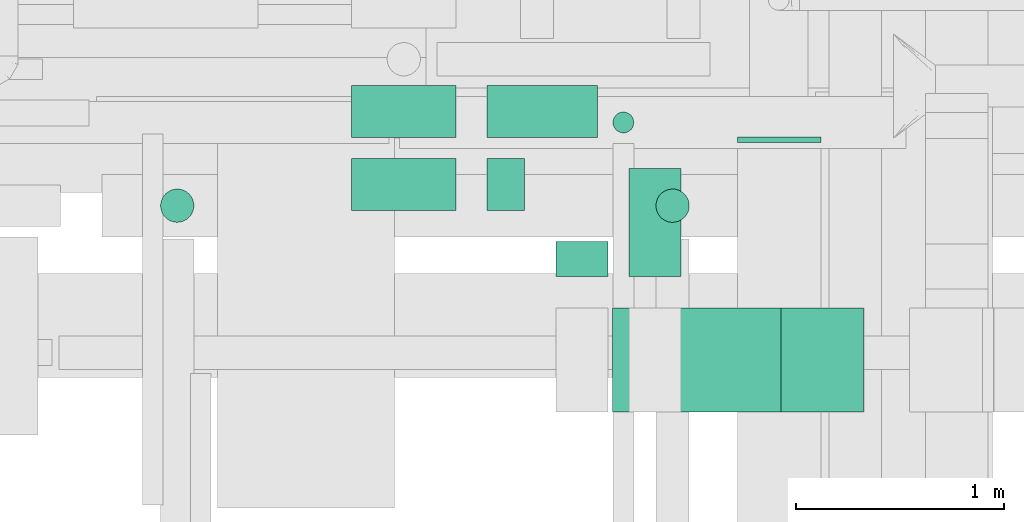
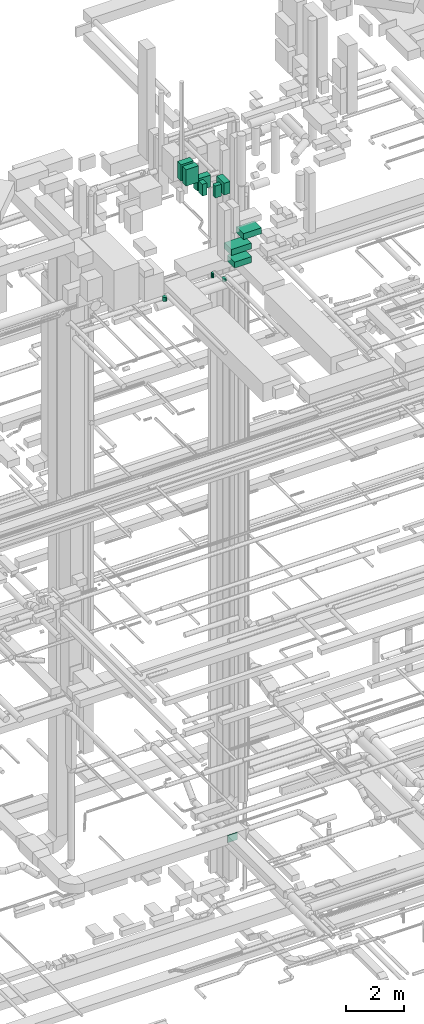
# One storey, part 130 of 337: 12 flow segments, 1 flow fitting.
"""IFC2X3 building model written with IfcOpenShell, lengths in millimetres."""

from ifc_helpers import new_model, entity, si_unit, converted_unit, derived_unit, direction, frame, origin, origin_2d_with_axis, place, context, subcontext, project, spatial, rectangle, circle, extrude, source, transform, mapped, material, type_object, type_shapes, element, save


model = new_model("IFC2X3")

# Units and contexts
model_context = context("Model", 3, precision=0.01, world=origin(), true_north=direction((6.12303176911189e-17, 1.0)))
body_context = subcontext(model_context, "Body", "Model", "MODEL_VIEW")
ifc_project = project(units=[si_unit("LENGTHUNIT", "METRE", prefix="MILLI"), si_unit("AREAUNIT", "SQUARE_METRE"), si_unit("VOLUMEUNIT", "CUBIC_METRE"), converted_unit("PLANEANGLEUNIT", "DEGREE", entity("IfcRatioMeasure", 0.0174532925199433), si_unit("PLANEANGLEUNIT", "RADIAN"), dimensions=[0, 0, 0, 0, 0, 0, 0]), si_unit("MASSUNIT", "GRAM", prefix="KILO"), derived_unit("MASSDENSITYUNIT", [(si_unit("MASSUNIT", "GRAM", prefix="KILO"), 1), (si_unit("LENGTHUNIT", "METRE"), -3)]), derived_unit("MOMENTOFINERTIAUNIT", [(si_unit("LENGTHUNIT", "METRE"), 4)]), si_unit("TIMEUNIT", "SECOND"), si_unit("FREQUENCYUNIT", "HERTZ"), si_unit("THERMODYNAMICTEMPERATUREUNIT", "DEGREE_CELSIUS"), derived_unit("THERMALTRANSMITTANCEUNIT", [(si_unit("MASSUNIT", "GRAM", prefix="KILO"), 1), (si_unit("THERMODYNAMICTEMPERATUREUNIT", "KELVIN"), -1), (si_unit("TIMEUNIT", "SECOND"), -3)]), derived_unit("VOLUMETRICFLOWRATEUNIT", [(si_unit("LENGTHUNIT", "METRE"), 3), (si_unit("TIMEUNIT", "SECOND"), -1)]), derived_unit("MASSFLOWRATEUNIT", [(si_unit("MASSUNIT", "GRAM", prefix="KILO"), 1), (si_unit("TIMEUNIT", "SECOND"), -1)]), derived_unit("ROTATIONALFREQUENCYUNIT", [(si_unit("TIMEUNIT", "SECOND"), -1)]), si_unit("ELECTRICCURRENTUNIT", "AMPERE"), si_unit("ELECTRICVOLTAGEUNIT", "VOLT"), si_unit("POWERUNIT", "WATT"), si_unit("FORCEUNIT", "NEWTON", prefix="KILO"), si_unit("ILLUMINANCEUNIT", "LUX"), si_unit("LUMINOUSFLUXUNIT", "LUMEN"), si_unit("LUMINOUSINTENSITYUNIT", "CANDELA"), derived_unit("USERDEFINED", [(si_unit("MASSUNIT", "GRAM", prefix="KILO"), -1), (si_unit("LENGTHUNIT", "METRE"), -2), (si_unit("TIMEUNIT", "SECOND"), 3), (si_unit("LUMINOUSFLUXUNIT", "LUMEN"), 1)]), derived_unit("LINEARVELOCITYUNIT", [(si_unit("LENGTHUNIT", "METRE"), 1), (si_unit("TIMEUNIT", "SECOND"), -1)]), si_unit("PRESSUREUNIT", "PASCAL"), derived_unit("USERDEFINED", [(si_unit("LENGTHUNIT", "METRE"), -2), (si_unit("MASSUNIT", "GRAM", prefix="KILO"), 1), (si_unit("TIMEUNIT", "SECOND"), -2)]), derived_unit("LINEARFORCEUNIT", [(si_unit("MASSUNIT", "GRAM", prefix="KILO"), 1), (si_unit("LENGTHUNIT", "METRE"), 1), (si_unit("TIMEUNIT", "SECOND"), -2), (si_unit("LENGTHUNIT", "METRE"), -1)]), derived_unit("PLANARFORCEUNIT", [(si_unit("MASSUNIT", "GRAM", prefix="KILO"), 1), (si_unit("LENGTHUNIT", "METRE"), 1), (si_unit("TIMEUNIT", "SECOND"), -2), (si_unit("LENGTHUNIT", "METRE"), -2)])], contexts=[model_context])

# Site, building, storey
site_placement = place(None, origin())
site = spatial("IfcSite", under=ifc_project, at=site_placement, CompositionType="ELEMENT")
building_placement = place(site_placement, origin())
building = spatial("IfcBuilding", under=site, at=building_placement, CompositionType="ELEMENT")
storey_placement = place(building_placement, origin())
storey = spatial("IfcBuildingStorey", under=building, at=storey_placement, CompositionType="ELEMENT", Elevation=0.0)

# Flow segments
duct_segment_type_1 = type_object("IfcDuctSegmentType", PredefinedType="NOTDEFINED")
flow_segment_1_placement = place(storey_placement, frame((28826.82, 9272.81, 27295.0)))
element("IfcFlowSegment", 1, at=flow_segment_1_placement, inside=storey, type_object=duct_segment_type_1, context=body_context, shape_type="SweptSolid", body=[
    extrude(circle(Radius=50.0, at=origin_2d_with_axis()), frame((51.6, 51.6, 0.0), z_axis=(0.0, 0.0, 1.0), x_axis=(-1.0, 0.0, 0.0)), (0.0, 0.0, 1.0), 204.999999999984),
])
flow_segment_2_placement = place(storey_placement, frame((29033.02, 8843.38, 27320.0)))
element("IfcFlowSegment", 2, at=flow_segment_2_placement, inside=storey, type_object=duct_segment_type_1, context=body_context, shape_type="SweptSolid", body=[
    extrude(circle(Radius=80.0, at=origin_2d_with_axis()), frame((81.6, 81.6, 0.0), z_axis=(0.0, 0.0, 1.0), x_axis=(-1.0, 0.0, 0.0)), (0.0, 0.0, 1.0), 120.000000000042),
])
flow_segment_3_placement = place(storey_placement, frame((26655.91, 8843.38, 27320.0)))
element("IfcFlowSegment", 3, at=flow_segment_3_placement, inside=storey, type_object=duct_segment_type_1, context=body_context, shape_type="SweptSolid", body=[
    extrude(circle(Radius=80.0, at=origin_2d_with_axis()), frame((81.6, 81.6, 0.0), z_axis=(0.0, 0.0, 1.0), x_axis=(-1.0, 0.0, 0.0)), (0.0, 0.0, 1.0), 170.000000000044),
])
duct_segment_type_2 = type_object("IfcDuctSegmentType", PredefinedType="NOTDEFINED")
flow_segment_4_placement = place(storey_placement, frame((27574.64, 9252.5, 31850.0)))
element("IfcFlowSegment", 4, at=flow_segment_4_placement, inside=storey, type_object=duct_segment_type_2, context=body_context, shape_type="SweptSolid", body=[
    extrude(rectangle(XDim=499.999999999999, YDim=249.999999999999, at=origin_2d_with_axis()), frame((250.0, 125.0, 0.0)), (0.0, 0.0, 1.0), 690.000050000046),
])
flow_segment_5_placement = place(storey_placement, frame((28224.64, 9252.5, 31200.0)))
element("IfcFlowSegment", 5, at=flow_segment_5_placement, inside=storey, type_object=duct_segment_type_2, context=body_context, shape_type="SweptSolid", body=[
    extrude(rectangle(XDim=530.363510000023, YDim=249.999999999999, at=origin_2d_with_axis()), frame((265.18, 125.0, 0.0)), (0.0, 0.0, 1.0), 499.999999999999),
])
flow_segment_6_placement = place(storey_placement, frame((28905.0, 8584.5, 31200.0)))
element("IfcFlowSegment", 6, at=flow_segment_6_placement, inside=storey, type_object=duct_segment_type_2, context=body_context, shape_type="SweptSolid", body=[
    extrude(rectangle(XDim=518.000000000006, YDim=249.999999999999, at=origin_2d_with_axis()), frame((125.0, 259.0, 0.0), z_axis=(0.0, 0.0, 1.0), x_axis=(0.0, -1.0, 0.0)), (0.0, 0.0, 1.0), 499.999999999999),
])
flow_segment_7_placement = place(storey_placement, frame((27574.64, 8902.5, 31850.0)))
element("IfcFlowSegment", 7, at=flow_segment_7_placement, inside=storey, type_object=duct_segment_type_2, context=body_context, shape_type="SweptSolid", body=[
    extrude(rectangle(XDim=499.999999999999, YDim=249.999999999999, at=origin_2d_with_axis()), frame((250.0, 125.0, 0.0)), (0.0, 0.0, 1.0), 690.000050000055),
])
flow_segment_8_placement = place(storey_placement, frame((28224.64, 8902.5, 31200.0)))
element("IfcFlowSegment", 8, at=flow_segment_8_placement, inside=storey, type_object=duct_segment_type_2, context=body_context, shape_type="SweptSolid", body=[
    extrude(rectangle(XDim=180.396820000075, YDim=250.000000000001, at=origin_2d_with_axis()), frame((90.2, 125.0, 0.0), z_axis=(0.0, 0.0, 1.0), x_axis=(-1.0, 0.0, 0.0)), (0.0, 0.0, 1.0), 499.999999999999),
])
flow_segment_9_placement = place(storey_placement, frame((28555.03, 8584.5, 31200.0)))
element("IfcFlowSegment", 9, at=flow_segment_9_placement, inside=storey, type_object=duct_segment_type_2, context=body_context, shape_type="SweptSolid", body=[
    extrude(rectangle(XDim=168.000000000076, YDim=249.999999999999, at=origin_2d_with_axis()), frame((125.0, 84.0, 0.0), z_axis=(0.0, 0.0, 1.0), x_axis=(0.0, 1.0, 0.0)), (0.0, 0.0, 1.0), 499.999999999999),
])
flow_segment_10_placement = place(storey_placement, frame((28955.03, 7934.5, 28500.0)))
element("IfcFlowSegment", 10, at=flow_segment_10_placement, inside=storey, type_object=duct_segment_type_2, context=body_context, shape_type="SweptSolid", body=[
    extrude(rectangle(XDim=678.817698821285, YDim=500.0, at=origin_2d_with_axis()), frame((339.41, 250.0, 0.0)), (0.0, 0.0, 1.0), 250.000000000004),
])
flow_segment_11_placement = place(storey_placement, frame((28825.03, 7934.5, 29075.0)))
element("IfcFlowSegment", 11, at=flow_segment_11_placement, inside=storey, type_object=duct_segment_type_2, context=body_context, shape_type="SweptSolid", body=[
    extrude(rectangle(XDim=800.808070089696, YDim=500.0, at=origin_2d_with_axis()), frame((400.4, 250.0, 0.0)), (0.0, 0.0, 1.0), 250.000000000004),
])
flow_segment_12_placement = place(storey_placement, frame((29305.0, 7934.5, 29575.0)))
element("IfcFlowSegment", 12, at=flow_segment_12_placement, inside=storey, type_object=duct_segment_type_2, context=body_context, shape_type="SweptSolid", body=[
    extrude(rectangle(XDim=725.358289414046, YDim=500.0, at=origin_2d_with_axis()), frame((362.68, 250.0, 0.0)), (0.0, 0.0, 1.0), 250.000000000004),
])

# Flow fitting
ifc_material = material()
duct_fitting_type = type_object("IfcDuctFittingType", PredefinedType="NOTDEFINED", material=ifc_material)
shared_shape = source(origin(), body_context, "Body", "SweptSolid", [
    extrude(rectangle(XDim=26.0960000000006, YDim=400.0, at=origin_2d_with_axis()), frame((6.95, 0.0, -150.0)), (0.0, 0.0, 1.0), 300.0),
])
type_shapes(duct_fitting_type, [shared_shape])
flow_fitting_placement = place(storey_placement, frame((29625.76, 9249.08, 3450.0), z_axis=(0.0, 0.0, -1.0), x_axis=(0.0, -1.0, 0.0)))
element("IfcFlowFitting", 13, at=flow_fitting_placement, inside=storey, type_object=duct_fitting_type, material=ifc_material, context=body_context, shape_type="MappedRepresentation", body=[
    mapped(shared_shape, transform((0.0, 0.0, 0.0), scale=1.0)),
])

save(model, "model.ifc")
